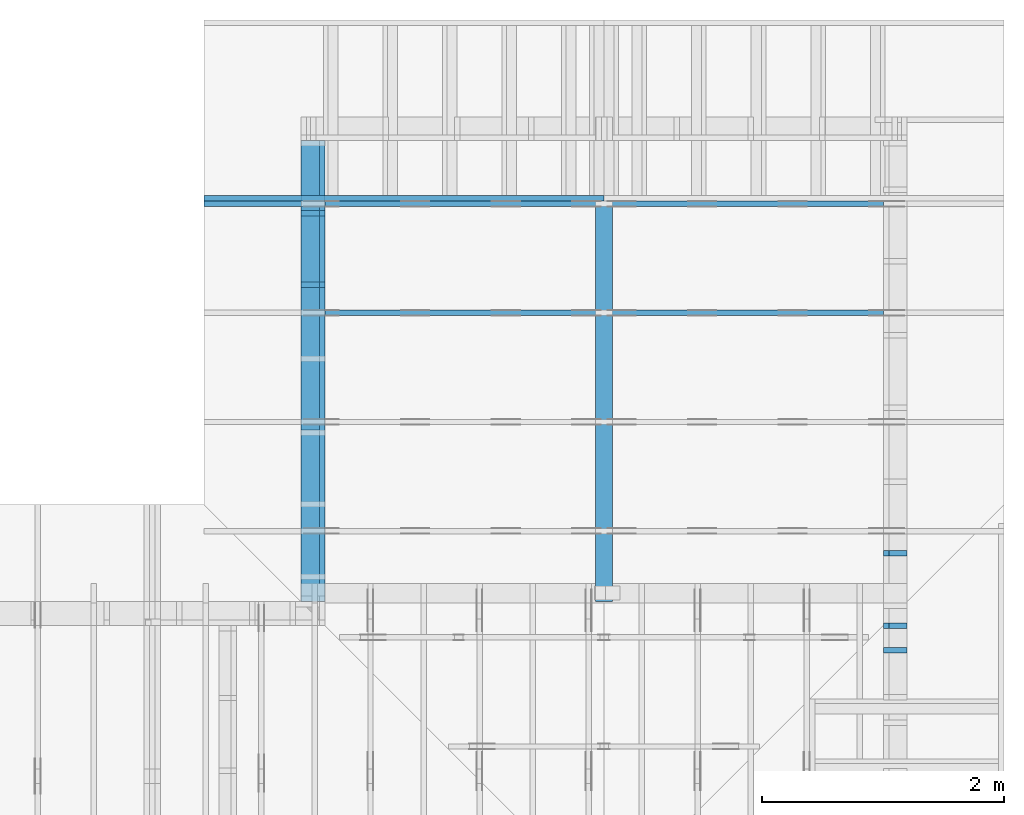
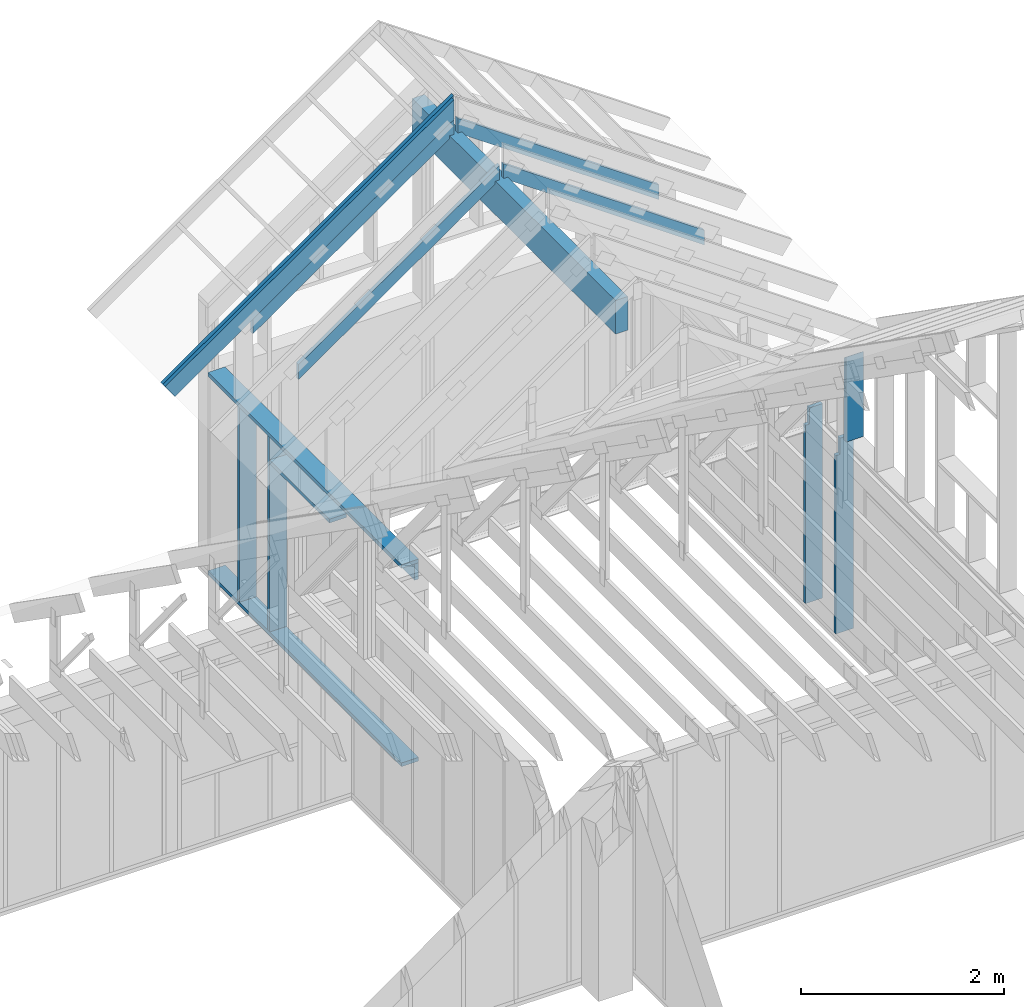
# One storey, part 32 of 70: 16 members, 9 elements without a shape of their own.
"""IFC2X3 building model written with IfcOpenShell, lengths in millimetres."""

from ifc_helpers import new_model, si_unit, frame, origin, origin_with_axes, origin_2d, place, context, project, spatial, faceted_brep, element, aggregate, save


model = new_model("IFC2X3")

# Units and contexts
model_context = context("Model", 3, precision=1e-05, world=origin())
plan_context = context("Plan", 2, precision=1e-05, world=origin_2d())
ifc_project = project(units=[si_unit("LENGTHUNIT", "METRE", prefix="MILLI"), si_unit("AREAUNIT", "SQUARE_METRE"), si_unit("VOLUMEUNIT", "CUBIC_METRE"), si_unit("SOLIDANGLEUNIT", "STERADIAN"), si_unit("PLANEANGLEUNIT", "RADIAN"), si_unit("MASSUNIT", "GRAM"), si_unit("TIMEUNIT", "SECOND"), si_unit("THERMODYNAMICTEMPERATUREUNIT", "DEGREE_CELSIUS"), si_unit("LUMINOUSINTENSITYUNIT", "LUMEN")], contexts=[model_context, plan_context])

# Site, building, storey
site_placement = place(None, origin_with_axes())
site = spatial("IfcSite", under=ifc_project, at=site_placement, CompositionType="ELEMENT")
building_placement = place(site_placement, origin_with_axes())
building = spatial("IfcBuilding", under=site, at=building_placement, Name="Layout 1", CompositionType="ELEMENT")
storey_placement = place(building_placement, origin_with_axes())
storey = spatial("IfcBuildingStorey", under=building, at=storey_placement, Name="Storey 1", CompositionType="ELEMENT", Elevation=0.0)

# Assembly, members
assembly_1_placement = place(storey_placement, frame((7000.0, 11305.0, 1.3776821480501744e-15), z_axis=(1.2246063538223773e-16, 1.0, 6.123031769111886e-17), x_axis=(-1.0, 1.2246063538223773e-16, 0.0)))
assembly_1 = element("IfcElementAssembly", 1, at=assembly_1_placement, inside=storey, Name="T4", AssemblyPlace="FACTORY", PredefinedType="TRUSS")
member_1_placement = place(assembly_1_placement, frame((-2589.347405088728, 2575.029527277477, -45.00000000000001), z_axis=(0.0, 0.0, 1.0), x_axis=(0.8191520442889916, -0.5735764363510465, 0.0)))
member_1 = element("IfcMember", 2, at=member_1_placement, Name="T11", context=model_context, shape_type="Brep", body=[
    faceted_brep([(4001.0887146659597, 194.99999999844545, 45.0), (0.0, 194.99999999844545, 45.0), (136.5404699499495, 1.8338823792873882e-09, 45.0), (4001.0887146652617, 1.8338823792873882e-09, 45.0), (0.0, 194.99999999844545, 0.0), (4001.0887146659597, 194.99999999844545, 4.899758662186943e-13), (4001.0887146652617, 1.8338823792873882e-09, 4.899758662186089e-13), (136.5404699499495, 1.8338823792873882e-09, 1.6720832705460153e-14), (136.54046994994948, 1.8338823792873882e-09, 7.888609052210118e-31), (136.54046994994948, 1.8338823792873882e-09, 45.0), (4.263256414560601e-14, 195.00000000048556, 45.0), (4.263256414560601e-14, 195.00000000048556, -3.1554436208840472e-30), (4001.0887146652617, 2.7584992468545714e-13, -1.6890378523536798e-29), (4001.0887146652617, 2.786052889815575e-13, 45.0), (136.5404699499495, 1.8338945482590892e-09, 45.0), (136.5404699499495, 1.833891792894793e-09, -5.763981720251638e-31), (4001.0887146652617, 194.99999999844545, -4.2712084852286463e-26), (4001.0887146652617, 194.99999999844545, 45.0), (4001.0887146652617, 0.0, 45.0), (4001.0887146652617, 0.0, 0.0), (0.0, 195.00000000048556, 0.0), (0.0, 195.00000000048556, 45.0), (4001.0887146659597, 194.9999999984455, 45.0), (4001.0887146659597, 194.9999999984455, 3.1554436208840472e-30)], [[[0, 1, 2, 3]], [[4, 5, 6, 7]], [[8, 9, 10, 11]], [[12, 13, 14, 15]], [[16, 17, 18, 19]], [[20, 21, 22, 23]]]),
])
member_2_placement = place(assembly_1_placement, frame((-111.83141672927059, 840.2541561936754, -44.99999999999999), z_axis=(0.0, 0.0, 1.0), x_axis=(-0.819152044288719, 0.5735764363514356, 0.0)))
member_2 = element("IfcMember", 3, at=member_2_placement, Name="SC2", context=model_context, shape_type="Brep", body=[
    faceted_brep([(2786.417998849913, 144.9999999982091, 45.0), (2745.0508206133427, 116.03438996246825, 45.0), (2724.7688821174256, 144.9999999982091, 45.0), (0.0, 144.9999999982091, 45.0), (101.53009304058673, 3.296918293926865e-12, 45.0), (2887.948091889168, 3.296918293926865e-12, 45.0), (0.0, 144.9999999982091, 0.0), (2724.7688821174256, 144.9999999982091, 3.3367692857384953e-13), (2745.0508206133427, 116.03438996246825, 3.36160667648843e-13), (2786.417998849913, 144.9999999982091, 3.412265185796637e-13), (2887.948091889168, 3.296918293926865e-12, 3.536599582836686e-13), (101.53009304058673, 3.296918293926865e-12, 1.2433439704167964e-14), (2786.417998849913, 144.99999999820875, -3.4361342959847526e-29), (2786.417998849913, 144.99999999820875, 45.0), (2887.948091889168, 2.9558577807620168e-12, 45.0), (2887.948091889168, 2.9558577807620168e-12, -3.545226557966541e-29), (2745.0508206133427, 116.03438996246814, -1.262177448353619e-29), (2745.0508206133427, 116.03438996246814, 45.0), (2786.417998849913, 144.99999999820898, 45.0), (2786.417998849913, 144.99999999820898, -1.262177448353619e-29), (2724.7688821174256, 144.99999999824877, 0.0), (2724.7688821174256, 144.99999999824877, 45.0), (2745.0508206133427, 116.03438996246837, 45.0), (2745.0508206133427, 116.03438996246837, 0.0), (0.0, 145.00000000000875, 0.0), (0.0, 145.00000000000875, 45.0), (2724.7688821174256, 144.99999999824857, 45.0), (2724.7688821174256, 144.99999999824857, -1.735493991486226e-29), (101.5300930405867, 0.0, 1.5777218104420236e-30), (101.5300930405867, 0.0, 45.0), (1.4210854715202004e-14, 145.00000000000875, 45.0), (1.4210854715202004e-14, 145.00000000000875, -7.888609052210118e-31), (2887.948091889168, 1.914391789805818e-12, 8.465253706372364e-29), (2887.948091889168, 1.9171471541019185e-12, 45.0), (101.53009304058673, -4.584940287014898e-14, 45.0), (101.53009304058673, -4.860476716624933e-14, 2.976085334892309e-30)], [[[0, 1, 2, 3, 4, 5]], [[6, 7, 8, 9, 10, 11]], [[12, 13, 14, 15]], [[16, 17, 18, 19]], [[20, 21, 22, 23]], [[24, 25, 26, 27]], [[28, 29, 30, 31]], [[32, 33, 34, 35]]]),
])
aggregate(assembly_1, [member_1, member_2])

# Assembly, member
assembly_2_placement = place(storey_placement, frame((7000.0, 10405.0, 1.3776821480501744e-15), z_axis=(1.2246063538223773e-16, 1.0, 6.123031769111886e-17), x_axis=(-1.0, 1.2246063538223773e-16, 0.0)))
assembly_2 = element("IfcElementAssembly", 4, at=assembly_2_placement, inside=storey, Name="T4", AssemblyPlace="FACTORY", PredefinedType="TRUSS")
member_3_placement = place(assembly_2_placement, frame((-111.83141672927059, 840.2541561936754, -44.99999999999999), z_axis=(0.0, 0.0, 1.0), x_axis=(-0.819152044288719, 0.5735764363514356, 0.0)))
member_3 = element("IfcMember", 5, at=member_3_placement, Name="SC2", context=model_context, shape_type="Brep", body=[
    faceted_brep([(2786.417998849913, 144.9999999982091, 45.0), (2745.0508206133427, 116.03438996246825, 45.0), (2724.7688821174256, 144.9999999982091, 45.0), (0.0, 144.9999999982091, 45.0), (101.53009304058673, 3.296918293926865e-12, 45.0), (2887.948091889168, 3.296918293926865e-12, 45.0), (0.0, 144.9999999982091, 0.0), (2724.7688821174256, 144.9999999982091, 3.3367692857384953e-13), (2745.0508206133427, 116.03438996246825, 3.36160667648843e-13), (2786.417998849913, 144.9999999982091, 3.412265185796637e-13), (2887.948091889168, 3.296918293926865e-12, 3.536599582836686e-13), (101.53009304058673, 3.296918293926865e-12, 1.2433439704167964e-14), (2786.417998849913, 144.99999999820875, -3.4361342959847526e-29), (2786.417998849913, 144.99999999820875, 45.0), (2887.948091889168, 2.9558577807620168e-12, 45.0), (2887.948091889168, 2.9558577807620168e-12, -3.545226557966541e-29), (2745.0508206133427, 116.03438996246814, -1.262177448353619e-29), (2745.0508206133427, 116.03438996246814, 45.0), (2786.417998849913, 144.99999999820898, 45.0), (2786.417998849913, 144.99999999820898, -1.262177448353619e-29), (2724.7688821174256, 144.99999999824877, 0.0), (2724.7688821174256, 144.99999999824877, 45.0), (2745.0508206133427, 116.03438996246837, 45.0), (2745.0508206133427, 116.03438996246837, 0.0), (0.0, 145.00000000000875, 0.0), (0.0, 145.00000000000875, 45.0), (2724.7688821174256, 144.99999999824857, 45.0), (2724.7688821174256, 144.99999999824857, -1.735493991486226e-29), (101.5300930405867, 0.0, 1.5777218104420236e-30), (101.5300930405867, 0.0, 45.0), (1.4210854715202004e-14, 145.00000000000875, 45.0), (1.4210854715202004e-14, 145.00000000000875, -7.888609052210118e-31), (2887.948091889168, 1.914391789805818e-12, 8.465253706372364e-29), (2887.948091889168, 1.9171471541019185e-12, 45.0), (101.53009304058673, -4.584940287014898e-14, 45.0), (101.53009304058673, -4.860476716624933e-14, 2.976085334892309e-30)], [[[0, 1, 2, 3, 4, 5]], [[6, 7, 8, 9, 10, 11]], [[12, 13, 14, 15]], [[16, 17, 18, 19]], [[20, 21, 22, 23]], [[24, 25, 26, 27]], [[28, 29, 30, 31]], [[32, 33, 34, 35]]]),
])
aggregate(assembly_2, [member_3])

# Assembly, members
assembly_3_placement = place(storey_placement, frame((7000.0, 11805.0, -2470.0), z_axis=(-1.0, 1.836909530733566e-16, 6.123031769111886e-17), x_axis=(-1.836909530733566e-16, -1.0, 0.0)))
assembly_3 = element("IfcElementAssembly", 6, at=assembly_3_placement, inside=storey, Name="VE1", AssemblyPlace="FACTORY", PredefinedType="NOTDEFINED")
member_4_placement = place(assembly_3_placement, frame((1.457281561048629e-13, 2425.0, -195.0), z_axis=(0.0, 0.0, 1.0), x_axis=(1.0, 0.0, 0.0)))
member_4 = element("IfcMember", 7, at=member_4_placement, Name="P8", context=model_context, shape_type="Brep", body=[
    faceted_brep([(3804.9999999981383, 45.0, 195.0), (2.755364296100349e-15, 45.0, 195.0), (0.0, 0.0, 195.0), (3804.9999999981383, 0.0, 195.0), (2.755364296100349e-15, 45.0, 3.3742366240998092e-31), (3804.9999999981383, 45.0, 4.659627176291865e-13), (3804.9999999981383, 0.0, 4.659627176291865e-13), (0.0, 0.0, 0.0), (0.0, 0.0, 0.0), (1.1939911949768178e-14, -1.462169203776584e-30, 195.0), (1.7450640541968876e-14, 45.0, 195.0), (5.510728592200698e-15, 45.0, -1.6871183120499046e-31), (3804.9999999981383, -6.989440764437798e-13, 4.2796567848978306e-29), (3804.9999999981383, -6.870041644940116e-13, 195.0), (2.193253805664876e-30, 1.1939911949768178e-14, 195.0), (0.0, 0.0, 0.0), (3804.9999999981383, 45.0, 0.0), (3804.9999999981383, 45.0, 195.0), (3804.9999999981383, 0.0, 195.0), (3804.9999999981383, 0.0, 0.0), (2.755364296100349e-15, 45.0, 0.0), (2.755364296100348e-15, 44.999999999999986, 195.0), (3804.9999999981383, 44.99999999999976, 195.0), (3804.9999999981383, 44.999999999999766, -1.4199496293978212e-29)], [[[0, 1, 2, 3]], [[4, 5, 6, 7]], [[8, 9, 10, 11]], [[12, 13, 14, 15]], [[16, 17, 18, 19]], [[20, 21, 22, 23]]]),
])
member_5_placement = place(assembly_3_placement, frame((3804.999999998138, 90.0, -195.0), z_axis=(0.0, 0.0, 1.0), x_axis=(-1.0, 1.2246063538223773e-16, 0.0)))
member_5 = element("IfcMember", 8, at=member_5_placement, Name="P8", context=model_context, shape_type="Brep", body=[
    faceted_brep([(3804.999999998138, 45.00000000000047, 195.0), (0.0, 45.00000000000047, 195.0), (0.0, 0.0, 195.0), (3804.999999998138, 0.0, 195.0), (0.0, 45.00000000000047, 0.0), (3804.999999998138, 45.00000000000047, 4.659627176291865e-13), (3804.999999998138, 0.0, 4.659627176291865e-13), (0.0, 0.0, 0.0), (0.0, 0.0, 0.0), (1.1939911949768178e-14, -1.462169203776584e-30, 195.0), (1.7450640541968876e-14, 45.0, 195.0), (5.510728592200698e-15, 45.0, -3.3742366240998092e-31), (3804.999999998138, -6.989440764437797e-13, 7.151102776182536e-29), (3804.999999998138, -6.870041644940115e-13, 195.0), (2.193253805664876e-30, 1.1939911949768178e-14, 195.0), (0.0, 0.0, 0.0), (3804.999999998138, 45.00000000000047, 0.0), (3804.999999998138, 45.00000000000047, 195.0), (3804.999999998138, 4.689582056016661e-13, 195.0), (3804.999999998138, 4.689582056016661e-13, 0.0), (0.0, 45.0, 0.0), (1.5777218104420236e-30, 44.999999999999986, 195.0), (3804.999999998138, 45.0000000000006, 195.0), (3804.999999998138, 45.00000000000061, 8.67746995743113e-30)], [[[0, 1, 2, 3]], [[4, 5, 6, 7]], [[8, 9, 10, 11]], [[12, 13, 14, 15]], [[16, 17, 18, 19]], [[20, 21, 22, 23]]]),
])
member_6_placement = place(assembly_3_placement, frame((1.3378824415499132e-13, 2229.9999999981374, -195.0), z_axis=(0.0, 0.0, 1.0), x_axis=(1.0, 0.0, 0.0)))
member_6 = element("IfcMember", 9, at=member_6_placement, Name="L4", context=model_context, shape_type="Brep", body=[
    faceted_brep([(3804.9999999981383, 195.00000000186265, 45.0), (1.1939911949871576e-14, 195.00000000186265, 45.0), (0.0, 0.0, 45.0), (3804.9999999981383, 0.0, 45.0), (1.1939911949871576e-14, 195.00000000186265, 1.4621692037892461e-30), (3804.9999999981383, 195.00000000186265, 4.659627176291865e-13), (3804.9999999981383, 0.0, 4.659627176291865e-13), (0.0, 0.0, 0.0), (0.0, 0.0, 0.0), (2.755364296100349e-15, -3.3742366240998092e-31, 45.0), (2.6635188195864806e-14, 195.00000000186265, 45.0), (2.3879823899764457e-14, 195.00000000186265, -7.310846018959277e-31), (3804.9999999981383, 1.8614159626370412e-09, 7.526348564713319e-29), (3804.9999999981383, 1.8614187180013373e-09, 45.0), (-1.3479314280272993e-27, 2.755364296100349e-15, 45.0), (0.0, 0.0, 0.0), (3804.9999999981383, 195.00000000186265, 0.0), (3804.9999999981383, 195.00000000186265, 45.0), (3804.9999999981383, 1.862645149230957e-09, 45.0), (3804.9999999981383, 1.862645149230957e-09, 0.0), (1.1939911949871576e-14, 195.00000000186265, 0.0), (1.1939911949871576e-14, 195.00000000186265, 45.0), (3804.9999999981383, 195.00000000186242, 45.0), (3804.9999999981383, 195.00000000186242, -1.4199496293978212e-29)], [[[0, 1, 2, 3]], [[4, 5, 6, 7]], [[8, 9, 10, 11]], [[12, 13, 14, 15]], [[16, 17, 18, 19]], [[20, 21, 22, 23]]]),
])
member_7_placement = place(assembly_3_placement, frame((577.5000000036821, 2425.0, -195.0), z_axis=(0.0, 0.0, 1.0), x_axis=(-1.836909530733566e-16, -1.0, 0.0)))
member_7 = element("IfcMember", 10, at=member_7_placement, Name="P10", context=model_context, shape_type="Brep", body=[
    faceted_brep([(0.0, 45.0000000000141, 45.0), (195.00000000186265, 45.0000000000141, 45.00000000000002), (195.00000000186265, 1.4097167877480388e-11, 45.00000000000002), (0.0, 1.4097167877480388e-11, 45.0), (195.00000000186265, 1.2846612662542611e-11, 0.0), (195.00000000186265, 1.2846612662542611e-11, 45.0), (195.00000000186265, 45.0000000000141, 45.0), (195.00000000186265, 45.0000000000141, 0.0), (2.7553642961020753e-15, 1.4097167877480388e-11, 45.0), (1.1939911949769904e-14, 1.4097167877480388e-11, 195.0), (1.7450640541970602e-14, 45.0000000000141, 195.0), (8.266092888302773e-15, 45.0000000000141, 45.0), (2335.0, 1.36682495020541e-11, 2.626280839091018e-29), (2335.0, 1.3680189414003868e-11, 195.0), (2.193253805664876e-30, 1.4109107789430156e-11, 195.0), (5.061354936149714e-31, 1.4099923241776488e-11, 45.0), (195.00000000186265, 1.4064103505926841e-11, 45.0), (195.00000000186265, 1.406134814163074e-11, 2.193253805685862e-30), (-1.6871183120499046e-31, 45.0000000000141, 45.0), (-7.31084601888292e-31, 45.00000000001408, 195.0), (2335.0, 45.00000000001394, 195.0), (2335.0, 45.000000000013955, -1.5777218104420236e-29), (195.00000000186265, 45.00000000001408, -7.888609052210118e-31), (195.00000000186265, 45.00000000001408, 45.0), (2335.0, 45.00000000001455, 0.0), (2335.0, 45.00000000001455, 195.0), (2335.0, 0.0, 195.0), (2335.0, 0.0, 0.0), (2335.0, 45.00000000001455, 195.0), (0.0, 45.00000000001455, 195.0), (0.0, 1.4097167877480388e-11, 195.0), (2335.0, 1.4097167877480388e-11, 195.0), (195.00000000186265, 45.0000000000141, 2.3879823899764457e-14), (2335.0, 45.0000000000141, 2.859455836175251e-13), (2335.0, 0.0, 2.859455836175251e-13), (195.00000000186265, 0.0, 2.3879823899764457e-14)], [[[0, 1, 2, 3]], [[4, 5, 6, 7]], [[8, 9, 10, 11]], [[12, 13, 14, 15, 16, 17]], [[18, 19, 20, 21, 22, 23]], [[24, 25, 26, 27]], [[28, 29, 30, 31]], [[32, 33, 34, 35]]]),
])
member_8_placement = place(assembly_3_placement, frame((1167.5000000055297, 2425.0, -195.0), z_axis=(0.0, 0.0, 1.0), x_axis=(-1.836909530733566e-16, -1.0, 0.0)))
member_8 = element("IfcMember", 11, at=member_8_placement, Name="S11", context=model_context, shape_type="Brep", body=[
    faceted_brep([(0.0, 45.0, 45.0), (195.00000000186265, 45.0, 45.00000000000002), (195.00000000186265, 0.0, 45.00000000000002), (0.0, 0.0, 45.0), (195.00000000186265, 1.1368683772161603e-12, 0.0), (195.00000000186265, 1.1368683772161603e-12, 45.0), (195.00000000186265, 45.0, 45.0), (195.00000000186265, 45.0, 0.0), (2.755364296100349e-15, -3.3742366240998092e-31, 45.0), (1.1939911949768178e-14, -1.462169203776584e-30, 195.0), (1.7450640541968876e-14, 45.0, 195.0), (8.266092888301046e-15, 45.0, 45.0), (2335.0, -4.2891837542628763e-13, 2.626280839091018e-29), (2335.0, -4.1697846347651946e-13, 195.0), (2.193253805664876e-30, 1.1939911949768178e-14, 195.0), (5.061354936149714e-31, 2.755364296100349e-15, 45.0), (195.00000000186265, -3.306437155354634e-14, 45.0), (195.00000000186265, -3.5819735849646686e-14, 2.193253805685826e-30), (-1.6871183120499046e-31, 45.0, 45.0), (-7.31084601888292e-31, 44.999999999999986, 195.0), (2335.0, 44.999999999999844, 195.0), (2335.0, 44.99999999999986, -8.67746995743113e-30), (195.00000000186265, 44.999999999999986, -7.888609052210118e-31), (195.00000000186265, 44.999999999999986, 45.0), (2335.0, 45.000000000000455, 2.842170943040401e-14), (2335.0, 45.000000000000455, 195.0), (2335.0, 1.5006662579253316e-11, 195.0), (2335.0, 1.5006662579253316e-11, 0.0), (2335.0, 45.000000000000455, 195.0), (0.0, 45.000000000000455, 195.0), (0.0, 0.0, 195.0), (2335.0, 0.0, 195.0), (195.00000000186265, 45.0, 2.3879823899764457e-14), (2335.0, 45.0, 2.859455836175251e-13), (2335.0, 1.5006662579253316e-11, 2.859455836175251e-13), (195.00000000186265, 1.5006662579253316e-11, 2.3879823899764457e-14)], [[[0, 1, 2, 3]], [[4, 5, 6, 7]], [[8, 9, 10, 11]], [[12, 13, 14, 15, 16, 17]], [[18, 19, 20, 21, 22, 23]], [[24, 25, 26, 27]], [[28, 29, 30, 31]], [[32, 33, 34, 35]]]),
])
member_9_placement = place(assembly_3_placement, frame((2387.5000000036816, 2154.9999999987776, -195.0), z_axis=(0.0, 0.0, 1.0), x_axis=(-1.0, 1.2246063538223773e-16, 0.0)))
member_9 = element("IfcMember", 12, at=member_9_placement, Name="S25", context=model_context, shape_type="Brep", body=[
    faceted_brep([(1174.9999999999852, 45.00000000001501, 195.0), (0.0, 45.00000000001501, 195.0), (0.0, 0.0, 195.0), (1174.9999999999852, 0.0, 195.0), (0.0, 45.00000000001501, 0.0), (1174.9999999999852, 45.00000000001501, 1.438912465741275e-13), (1174.9999999999852, 0.0, 1.438912465741275e-13), (0.0, 0.0, 0.0), (0.0, 0.0, 0.0), (1.1939911949768178e-14, -1.462169203776584e-30, 195.0), (1.745064054197066e-14, 45.00000000001455, 195.0), (5.51072859220248e-15, 45.00000000001455, -3.3742366241009005e-31), (1174.9999999999852, -2.1583686986119127e-13, 4.106008487503032e-29), (1174.9999999999852, -2.0389695791142309e-13, 195.0), (2.193253805664876e-30, 1.1939911949768178e-14, 195.0), (0.0, 0.0, 0.0), (1174.9999999999852, 45.00000000001501, 0.0), (1174.9999999999852, 45.00000000001501, 195.0), (1174.9999999999852, 4.547473508864641e-13, 195.0), (1174.9999999999852, 4.547473508864641e-13, 0.0), (0.0, 45.00000000001455, 0.0), (3.1554436208840472e-30, 45.00000000001454, 195.0), (1174.9999999999852, 45.00000000001499, 195.0), (1174.9999999999852, 45.000000000015, -3.944304526105059e-31)], [[[0, 1, 2, 3]], [[4, 5, 6, 7]], [[8, 9, 10, 11]], [[12, 13, 14, 15]], [[16, 17, 18, 19]], [[20, 21, 22, 23]]]),
])
aggregate(assembly_3, [member_4, member_5, member_6, member_7, member_8, member_9])

assembly_4_placement = place(storey_placement, frame((12000.0, 0.0, -2470.0), z_axis=(1.0, -6.123031769111886e-17, 6.123031769111886e-17), x_axis=(6.123031769111886e-17, 1.0, 0.0)))
assembly_4 = element("IfcElementAssembly", 13, at=assembly_4_placement, inside=storey, Name="VE5", AssemblyPlace="FACTORY", PredefinedType="NOTDEFINED")
member_10_placement = place(assembly_4_placement, frame((7777.500000001819, 2425.0, -195.00000000000003), z_axis=(0.0, 0.0, 1.0), x_axis=(-1.836909530733566e-16, -1.0, 0.0)))
member_10 = element("IfcMember", 14, at=member_10_placement, Name="S11", context=model_context, shape_type="Brep", body=[
    faceted_brep([(0.0, 45.00000000001455, 45.00000000000003), (195.00000000186265, 45.00000000001455, 45.00000000000005), (195.00000000186265, 1.4551915228366852e-11, 45.00000000000005), (0.0, 1.4551915228366852e-11, 45.00000000000003), (195.00000000186265, 1.3642420526593924e-11, 2.842170943040401e-14), (195.00000000186265, 1.3642420526593924e-11, 45.00000000000003), (195.00000000186265, 45.00000000001364, 45.00000000000003), (195.00000000186265, 45.00000000001364, 2.842170943040401e-14), (2.7553642961021324e-15, 1.4551915228366852e-11, 45.00000000000003), (1.1939911949769961e-14, 1.4551915228366852e-11, 195.00000000000003), (1.745064054197066e-14, 45.00000000001455, 195.00000000000003), (8.26609288830283e-15, 45.00000000001455, 45.00000000000003), (2335.0, 1.4122996852940564e-11, 2.842170943040403e-14), (2335.0, 1.4134936764890332e-11, 195.00000000000003), (2.1932538056648764e-30, 1.456385514031662e-11, 195.00000000000003), (5.061354936149717e-31, 1.4554670592662952e-11, 45.00000000000003), (195.00000000186265, 1.4518850856813305e-11, 45.00000000000003), (195.00000000186265, 1.4516095492517205e-11, 2.8421709430404014e-14), (-1.6871183120499057e-31, 45.00000000001364, 45.00000000000003), (-7.310846018882921e-31, 45.00000000001363, 195.00000000000003), (2335.0, 45.000000000013486, 195.00000000000003), (2335.0, 45.0000000000135, 2.8421709430403998e-14), (195.00000000186265, 45.00000000001363, 2.842170943040401e-14), (195.00000000186265, 45.00000000001363, 45.00000000000003), (2335.0, 45.0, 0.0), (2335.0, 45.0, 195.00000000000003), (2335.0, 0.0, 195.00000000000003), (2335.0, 0.0, 0.0), (2335.0, 45.0, 195.00000000000003), (0.0, 45.0, 195.00000000000003), (0.0, 1.4551915228366852e-11, 195.00000000000003), (2335.0, 1.4551915228366852e-11, 195.00000000000003), (195.00000000186265, 45.00000000001364, 5.2301533330168465e-14), (2335.0, 45.00000000001364, 3.143672930479291e-13), (2335.0, 0.0, 3.143672930479291e-13), (195.00000000186265, 0.0, 5.2301533330168465e-14)], [[[0, 1, 2, 3]], [[4, 5, 6, 7]], [[8, 9, 10, 11]], [[12, 13, 14, 15, 16, 17]], [[18, 19, 20, 21, 22, 23]], [[24, 25, 26, 27]], [[28, 29, 30, 31]], [[32, 33, 34, 35]]]),
])
member_11_placement = place(assembly_4_placement, frame((8377.500000001819, 2425.0, -195.00000000000003), z_axis=(0.0, 0.0, 1.0), x_axis=(-1.836909530733566e-16, -1.0, 0.0)))
member_11 = element("IfcMember", 15, at=member_11_placement, Name="S11", context=model_context, shape_type="Brep", body=[
    faceted_brep([(0.0, 45.00000000001455, 45.00000000000003), (195.00000000186265, 45.00000000001455, 45.00000000000005), (195.00000000186265, 1.4551915228366852e-11, 45.00000000000005), (0.0, 1.4551915228366852e-11, 45.00000000000003), (195.00000000186265, 1.2732925824820995e-11, 2.842170943040401e-14), (195.00000000186265, 1.2732925824820995e-11, 45.00000000000003), (195.00000000186265, 45.00000000001273, 45.00000000000003), (195.00000000186265, 45.00000000001273, 2.842170943040401e-14), (2.7553642961021324e-15, 1.4551915228366852e-11, 45.00000000000003), (1.1939911949769961e-14, 1.4551915228366852e-11, 195.00000000000003), (1.745064054197066e-14, 45.00000000001455, 195.00000000000003), (8.26609288830283e-15, 45.00000000001455, 45.00000000000003), (2335.0, 1.4122996852940564e-11, 2.842170943040403e-14), (2335.0, 1.4134936764890332e-11, 195.00000000000003), (2.1932538056648764e-30, 1.456385514031662e-11, 195.00000000000003), (5.061354936149717e-31, 1.4554670592662952e-11, 45.00000000000003), (195.00000000186265, 1.4518850856813305e-11, 45.00000000000003), (195.00000000186265, 1.4516095492517205e-11, 2.8421709430404014e-14), (-1.6871183120499057e-31, 45.00000000001273, 45.00000000000003), (-7.310846018882921e-31, 45.00000000001272, 195.00000000000003), (2335.0, 45.00000000001258, 195.00000000000003), (2335.0, 45.00000000001259, 2.8421709430403998e-14), (195.00000000186265, 45.00000000001272, 2.842170943040401e-14), (195.00000000186265, 45.00000000001272, 45.00000000000003), (2335.0, 45.0, 0.0), (2335.0, 45.0, 195.00000000000003), (2335.0, 0.0, 195.00000000000003), (2335.0, 0.0, 0.0), (2335.0, 45.0, 195.00000000000003), (0.0, 45.0, 195.00000000000003), (0.0, 1.4551915228366852e-11, 195.00000000000003), (2335.0, 1.4551915228366852e-11, 195.00000000000003), (195.00000000186265, 45.00000000001273, 5.2301533330168465e-14), (2335.0, 45.00000000001273, 3.143672930479291e-13), (2335.0, 0.0, 3.143672930479291e-13), (195.00000000186265, 0.0, 5.2301533330168465e-14)], [[[0, 1, 2, 3]], [[4, 5, 6, 7]], [[8, 9, 10, 11]], [[12, 13, 14, 15, 16, 17]], [[18, 19, 20, 21, 22, 23]], [[24, 25, 26, 27]], [[28, 29, 30, 31]], [[32, 33, 34, 35]]]),
])
aggregate(assembly_4, [member_10, member_11])

# Assembly, member
assembly_5_placement = place(storey_placement, frame((9569.999999999996, 8070.0, -192.76698497682128), z_axis=(1.0, -6.123031769111886e-17, 6.123031769111886e-17), x_axis=(6.123031769111886e-17, 1.0, 0.0)))
assembly_5 = element("IfcElementAssembly", 16, at=assembly_5_placement, inside=storey, Name="B2", AssemblyPlace="FACTORY", PredefinedType="TRUSS")
member_12_placement = place(assembly_5_placement, frame((-70.00000000000007, 2107.4678007140756, -140.0), z_axis=(0.0, 0.0, 1.0), x_axis=(1.0, 0.0, 0.0)))
member_12 = element("IfcMember", 17, at=member_12_placement, Name="G2", context=model_context, shape_type="Brep", body=[
    faceted_brep([(4000.0000000000005, 405.00000000186265, 140.0), (7.105427357601002e-14, 405.00000000186265, 140.0), (0.0, 0.0, 140.0), (4000.0000000000005, 0.0, 140.0), (7.105427357601002e-14, 405.00000000186265, 8.701351488741532e-30), (4000.0000000000005, 405.00000000186265, 4.89842541528951e-13), (4000.0000000000005, 0.0, 4.89842541528951e-13), (0.0, 0.0, 0.0), (-1.262177448353619e-29, 1.545670522905157e-45, 7.728352614525786e-46), (8.572244476756628e-15, -1.0497625052754946e-30, 140.0), (5.816880180679101e-14, 405.00000000186265, 140.0), (4.959655733003437e-14, 405.00000000186265, 1.3138627826669714e-30), (4000.0000000000005, -7.347638122934265e-13, 4.498982165466413e-29), (4000.0000000000005, -7.261915678166698e-13, 140.0), (1.5746437579132443e-30, 8.572244476756641e-15, 140.0), (0.0, 0.0, 0.0), (4000.0000000000005, 405.00000000186265, 0.0), (4000.0000000000005, 405.00000000186265, 140.0), (4000.0000000000005, 0.0, 140.0), (4000.0000000000005, 0.0, 0.0), (7.105427357601002e-14, 405.00000000186265, 0.0), (7.105427357601002e-14, 405.00000000186265, 140.0), (4000.0000000000005, 405.0000000018624, 140.0), (4000.0000000000005, 405.0000000018624, -1.5777218104420236e-29)], [[[0, 1, 2, 3]], [[4, 5, 6, 7]], [[8, 9, 10, 11]], [[12, 13, 14, 15]], [[16, 17, 18, 19]], [[20, 21, 22, 23]]]),
])
aggregate(assembly_5, [member_12])

assembly_6_placement = place(storey_placement, frame((12000.0, 10405.0, 1.3776821480501744e-15), z_axis=(1.2246063538223773e-16, 1.0, 6.123031769111886e-17), x_axis=(-1.0, 1.2246063538223773e-16, 0.0)))
assembly_6 = element("IfcElementAssembly", 18, at=assembly_6_placement, inside=storey, Name="T10", AssemblyPlace="FACTORY", PredefinedType="TRUSS")
member_13_placement = place(assembly_6_placement, frame((194.9999999995092, 721.4771097712946, -45.0), z_axis=(0.0, 0.0, 1.0), x_axis=(0.8191520442887201, 0.5735764363514341, 0.0)))
member_13 = element("IfcMember", 19, at=member_13_placement, Name="SC3", context=model_context, shape_type="Brep", body=[
    faceted_brep([(2887.9480918911295, 145.00000000153284, 45.0), (101.53009304036573, 145.00000000153284, 45.0), (0.0, 0.0, 45.0), (2786.417998849739, 0.0, 45.0), (101.53009304036573, 145.00000000153284, 1.24334397041409e-14), (2887.9480918911295, 145.00000000153284, 3.536599582839088e-13), (2786.417998849739, 0.0, 3.412265185796424e-13), (0.0, 0.0, 0.0), (0.0, 0.0, 0.0), (2.257062295911826e-15, -1.5804120338056804e-15, 45.0), (101.53009304036573, 145.00000000000352, 45.0), (101.53009304036573, 145.00000000000352, 0.0), (2786.417998849739, 2.7666982972447333e-10, -8.780400618266663e-29), (2786.417998849739, 2.7667258508876943e-10, 45.0), (-2.7358643640174327e-28, 2.755364296100349e-15, 45.0), (0.0, 0.0, 0.0), (2887.9480918911295, 145.00000000153273, -1.0940736677918797e-29), (2887.9480918911295, 145.00000000153273, 45.0), (2786.417998849739, 2.75349520961754e-10, 45.0), (2786.417998849739, 2.75349520961754e-10, -9.849814058077961e-30), (101.53009304036573, 145.00000000000352, 0.0), (101.53009304036573, 145.0000000000035, 45.0), (2887.9480918911295, 145.00000000153278, 45.0), (2887.9480918911295, 145.00000000153278, -1.5777218104420236e-30)], [[[0, 1, 2, 3]], [[4, 5, 6, 7]], [[8, 9, 10, 11]], [[12, 13, 14, 15]], [[16, 17, 18, 19]], [[20, 21, 22, 23]]]),
])
aggregate(assembly_6, [member_13])

assembly_7_placement = place(storey_placement, frame((12000.0, 11305.0, 1.3776821480501744e-15), z_axis=(1.2246063538223773e-16, 1.0, 6.123031769111886e-17), x_axis=(-1.0, 1.2246063538223773e-16, 0.0)))
assembly_7 = element("IfcElementAssembly", 20, at=assembly_7_placement, inside=storey, Name="T10", AssemblyPlace="FACTORY", PredefinedType="TRUSS")
member_14_placement = place(assembly_7_placement, frame((194.9999999995092, 721.4771097712946, -45.0), z_axis=(0.0, 0.0, 1.0), x_axis=(0.8191520442887201, 0.5735764363514341, 0.0)))
member_14 = element("IfcMember", 21, at=member_14_placement, Name="SC3", context=model_context, shape_type="Brep", body=[
    faceted_brep([(2887.9480918911295, 145.00000000153284, 45.0), (101.53009304036573, 145.00000000153284, 45.0), (0.0, 0.0, 45.0), (2786.417998849739, 0.0, 45.0), (101.53009304036573, 145.00000000153284, 1.24334397041409e-14), (2887.9480918911295, 145.00000000153284, 3.536599582839088e-13), (2786.417998849739, 0.0, 3.412265185796424e-13), (0.0, 0.0, 0.0), (0.0, 0.0, 0.0), (2.257062295911826e-15, -1.5804120338056804e-15, 45.0), (101.53009304036573, 145.00000000000352, 45.0), (101.53009304036573, 145.00000000000352, 0.0), (2786.417998849739, 2.7666982972447333e-10, -8.780400618266663e-29), (2786.417998849739, 2.7667258508876943e-10, 45.0), (-2.7358643640174327e-28, 2.755364296100349e-15, 45.0), (0.0, 0.0, 0.0), (2887.9480918911295, 145.00000000153273, -1.0940736677918797e-29), (2887.9480918911295, 145.00000000153273, 45.0), (2786.417998849739, 2.75349520961754e-10, 45.0), (2786.417998849739, 2.75349520961754e-10, -9.849814058077961e-30), (101.53009304036573, 145.00000000000352, 0.0), (101.53009304036573, 145.0000000000035, 45.0), (2887.9480918911295, 145.00000000153278, 45.0), (2887.9480918911295, 145.00000000153278, -1.5777218104420236e-30)], [[[0, 1, 2, 3]], [[4, 5, 6, 7]], [[8, 9, 10, 11]], [[12, 13, 14, 15]], [[16, 17, 18, 19]], [[20, 21, 22, 23]]]),
])
aggregate(assembly_7, [member_14])

assembly_8_placement = place(storey_placement, frame((11805.0, 8000.000000000002, 1.1939911949768178e-14), z_axis=(-1.0, 1.836909530733566e-16, 6.123031769111886e-17), x_axis=(-1.836909530733566e-16, -1.0, 0.0)))
assembly_8 = element("IfcElementAssembly", 22, at=assembly_8_placement, inside=storey, Name="VE9", AssemblyPlace="FACTORY", PredefinedType="NOTDEFINED")
member_15_placement = place(assembly_8_placement, frame((377.50000000183354, 1063.8905130313433, -195.0), z_axis=(0.0, 0.0, 1.0), x_axis=(-1.836909530733566e-16, -1.0, 0.0)))
member_15 = element("IfcMember", 23, at=member_15_placement, Name="S30", context=model_context, shape_type="Brep", body=[
    faceted_brep([(1018.8905130313432, 44.99999999998562, 195.0), (0.0, 44.99999999998562, 195.0), (31.509339219424874, 0.0, 195.0), (1018.8905130313432, 0.0, 195.0), (0.0, 44.99999999998562, 0.0), (1018.8905130313432, 44.99999999998562, 1.2477397961075245e-13), (1018.8905130313432, 0.0, 1.2477397961075245e-13), (31.509339219424874, 0.0, 3.8586537012852325e-15), (31.509339219424874, 0.0, 1.9721522630525295e-31), (31.50933921942488, 7.105427357601002e-15, 195.0), (2.1316282072803006e-14, 45.000000000000014, 195.0), (1.0658141036401503e-14, 45.00000000000001, -7.888609052210118e-31), (1018.8905130313432, -1.9260293635285567e-13, 2.2234760767617538e-29), (1018.8905130313432, -1.806630244030875e-13, 195.0), (31.509339219424874, 7.099644611133235e-16, 195.0), (31.509339219424874, -1.1229947488654855e-14, 6.876132523849192e-31), (1018.8905130313432, 44.99999999998562, 0.0), (1018.8905130313432, 44.99999999998562, 195.0), (1018.8905130313432, 1.7053025658242404e-13, 195.0), (1018.8905130313432, 1.7053025658242404e-13, 0.0), (0.0, 45.0, 0.0), (-2.0194839173657902e-28, 44.999999999999986, 195.0), (1018.8905130313433, 44.999999999985896, 195.0), (1018.8905130313433, 44.99999999998591, 1.8143800820083272e-29)], [[[0, 1, 2, 3]], [[4, 5, 6, 7]], [[8, 9, 10, 11]], [[12, 13, 14, 15]], [[16, 17, 18, 19]], [[20, 21, 22, 23]]]),
])
aggregate(assembly_8, [member_15])

assembly_9_placement = place(storey_placement, frame((9499.999999999996, 12800.0, 2750.5188455242724), z_axis=(-0.5735764363510464, 8.131391261780321e-17, 0.8191520442889916), x_axis=(-0.8191520442889916, 1.3543414723620324e-16, -0.5735764363510464)))
assembly_9 = element("IfcElementAssembly", 24, at=assembly_9_placement, inside=storey, Name="gs4", AssemblyPlace="FACTORY", PredefinedType="TRUSS")
member_16_placement = place(assembly_9_placement, frame((-8.266092888301046e-15, 1450.0, -145.00000000000003), z_axis=(0.0, 0.0, 1.0), x_axis=(1.0, 0.0, 0.0)))
member_16 = element("IfcMember", 25, at=member_16_placement, Name="T4", context=model_context, shape_type="Brep", body=[
    faceted_brep([(101.5300930407283, 7.991580985960994e-13, 7.105427357601002e-15), (2.7000623958883807e-13, 1.0097419586828951e-28, 145.00000000000023), (2.842170943040401e-14, 45.00000000000001, 145.00000000000006), (101.53009304072795, 45.0000000000008, 0.0), (4028.5561429132804, -7.400093174012658e-13, 2.842170943040405e-14), (4028.5561429132804, -7.311309213360535e-13, 145.00000000000003), (1.6308810349815748e-30, 8.878396065212237e-15, 145.00000000000003), (101.53009304072832, -1.865015955627795e-14, 2.842170943040401e-14), (101.53009304072795, 45.0, 4.085514913458926e-14), (4028.5561429132804, 45.0, 5.217612543645812e-13), (4028.5561429132804, 0.0, 5.217612543645812e-13), (101.53009304072832, 0.0, 4.085514913458931e-14), (8.266092888301046e-15, 44.99999999999999, 145.00000000000003), (4028.5561429132804, 44.999999999999744, 145.00000000000003), (4028.5561429132804, 44.99999999999975, 2.8421709430403992e-14), (101.53009304072795, 44.99999999999999, 2.842170943040401e-14), (4028.5561429132804, 45.0, 5.684341886080802e-14), (4028.5561429132804, 45.0, 145.00000000000003), (4028.5561429132804, 0.0, 145.00000000000003), (4028.5561429132804, 0.0, 2.842170943040401e-14), (4028.5561429132804, 45.0, 145.00000000000003), (8.266092888301046e-15, 45.0, 145.00000000000003), (8.266092888301046e-15, 0.0, 145.00000000000003), (4028.5561429132804, 0.0, 145.00000000000003)], [[[0, 1, 2, 3]], [[4, 5, 6, 7]], [[8, 9, 10, 11]], [[12, 13, 14, 15]], [[16, 17, 18, 19]], [[20, 21, 22, 23]]]),
])
aggregate(assembly_9, [member_16])

save(model, "model.ifc")
